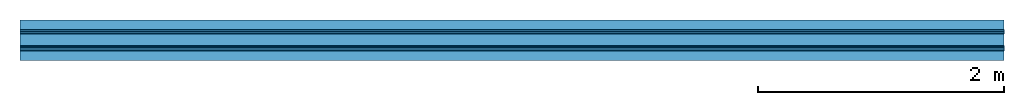
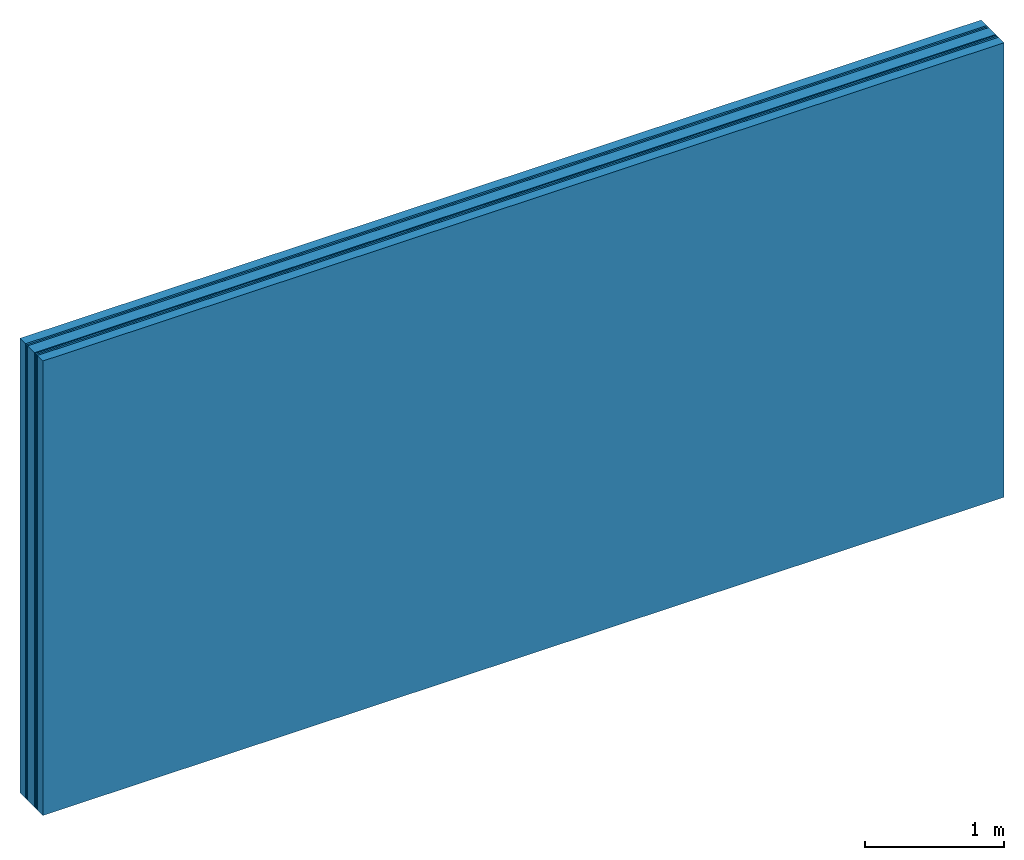
# One storey: 6 plates, 2 members, 1 element without a shape of its own.
"""IFC4 building model written with IfcOpenShell, lengths in metres."""

from ifc_helpers import new_model, si_unit, derived_unit, direction, frame, frame_2d, origin, place, context, project, spatial, rectangle, extrude, material, layer, layer_set, type_object, element, aggregate, save


model = new_model("IFC4")

# Units and contexts
plan_context = context("Plan", 3, precision=1e-05, world=origin(), true_north=direction((0.0, 1.0)))
model_context = context("Model", 3, precision=1e-05, world=origin(), true_north=direction((0.0, 1.0)))
ifc_project = project(units=[si_unit("LENGTHUNIT", "METRE"), derived_unit("SOUNDPRESSUREUNIT", [(si_unit("PRESSUREUNIT", "PASCAL", prefix="MICRO"), 0)]), si_unit("ENERGYUNIT", "JOULE", prefix="MEGA"), si_unit("MASSUNIT", "GRAM", prefix="KILO"), derived_unit("THERMALTRANSMITTANCEUNIT", [(si_unit("POWERUNIT", "WATT"), 1), (si_unit("AREAUNIT", "SQUARE_METRE"), -1), (si_unit("THERMODYNAMICTEMPERATUREUNIT", "KELVIN"), -1)]), derived_unit("AREADENSITYUNIT", [(si_unit("MASSUNIT", "GRAM", prefix="KILO"), 1), (si_unit("AREAUNIT", "SQUARE_METRE"), -1)]), derived_unit("USERDEFINED", [(si_unit("ENERGYUNIT", "JOULE", prefix="MEGA"), 1), (si_unit("AREAUNIT", "SQUARE_METRE"), -1)])], contexts=[plan_context, model_context])

# Site, building, storey
site = spatial("IfcSite", under=ifc_project)
building_placement = place(None, origin())
building = spatial("IfcBuilding", under=site, at=building_placement)
storey_placement = place(building_placement, origin())
storey = spatial("IfcBuildingStorey", under=building, at=storey_placement)

# Wall, members, plates
ifc_material_1 = material(Name="of the art")
ifc_layer_1 = layer(ifc_material_1, 0.0, Name="Bond")
ifc_layer_2 = layer(None, 0.08, Name="Support")
ifc_layer_3 = layer(ifc_material_1, 0.0, Name="Bond")
ifc_material_2 = material(Category="03.007")
ifc_layer_4 = layer(ifc_material_2, 0.015, Name="outside 1st layer")
ifc_layer_5 = layer(ifc_material_2, 0.015, Name="outside 2nd layer")
ifc_material_3 = material(Category="10.008")
ifc_layer_6 = layer(ifc_material_3, 0.1, Name="Intermediate insulation")
ifc_material_4 = material(Name="Air")
ifc_layer_7 = layer(ifc_material_4, 0.01, Name="Air gap")
ifc_layer_8 = layer(ifc_material_2, 0.015, Name="2nd layer")
ifc_layer_9 = layer(ifc_material_2, 0.015, Name="outside 1st layer")
ifc_layer_10 = layer(ifc_material_1, 0.0, Name="Bond")
ifc_layer_11 = layer(None, 0.08, Name="Support")
ifc_layer_12 = layer(ifc_material_1, 0.0, Name="Bond")
ifc_layer_set = layer_set([ifc_layer_1, ifc_layer_2, ifc_layer_3, ifc_layer_4, ifc_layer_5, ifc_layer_6, ifc_layer_7, ifc_layer_8, ifc_layer_9, ifc_layer_10, ifc_layer_11, ifc_layer_12])
wall_type = type_object("IfcWallType", Name="B0262", PredefinedType="NOTDEFINED", material=ifc_layer_set)
wall_placement = place(None, frame((0.0, 0.0, 0.0), z_axis=(0.0, -1.0, 0.0), x_axis=(1.0, 0.0, 0.0)))
wall = element("IfcWall", 1, at=wall_placement, inside=storey, type_object=wall_type, material=ifc_layer_set, Name="Wall #1")
ifc_material_5 = material(Name="Solid timber panel")
member_1_placement = place(wall_placement, origin())
member_1 = element("IfcMember", 2, at=member_1_placement, material=ifc_material_5, Name="Support", context=plan_context, shape_type="SweptSolid", body=[
    extrude(rectangle(XDim=1.0, YDim=0.08, at=frame_2d((0.5, 0.04), x_axis=(1.0, 0.0))), frame((0.0, 4.0, 0.0), z_axis=(0.0, -1.0, 0.0), x_axis=(1.0, 0.0, 0.0)), (0.0, 0.0, 1.0), 4.0),
    extrude(rectangle(XDim=1.0, YDim=0.08, at=frame_2d((0.5, 0.04), x_axis=(1.0, 0.0))), frame((1.0, 4.0, 0.0), z_axis=(0.0, -1.0, 0.0), x_axis=(1.0, 0.0, 0.0)), (0.0, 0.0, 1.0), 4.0),
    extrude(rectangle(XDim=1.0, YDim=0.08, at=frame_2d((0.5, 0.04), x_axis=(1.0, 0.0))), frame((2.0, 4.0, 0.0), z_axis=(0.0, -1.0, 0.0), x_axis=(1.0, 0.0, 0.0)), (0.0, 0.0, 1.0), 4.0),
    extrude(rectangle(XDim=1.0, YDim=0.08, at=frame_2d((0.5, 0.04), x_axis=(1.0, 0.0))), frame((3.0, 4.0, 0.0), z_axis=(0.0, -1.0, 0.0), x_axis=(1.0, 0.0, 0.0)), (0.0, 0.0, 1.0), 4.0),
    extrude(rectangle(XDim=1.0, YDim=0.08, at=frame_2d((0.5, 0.04), x_axis=(1.0, 0.0))), frame((4.0, 4.0, 0.0), z_axis=(0.0, -1.0, 0.0), x_axis=(1.0, 0.0, 0.0)), (0.0, 0.0, 1.0), 4.0),
    extrude(rectangle(XDim=1.0, YDim=0.08, at=frame_2d((0.5, 0.04), x_axis=(1.0, 0.0))), frame((5.0, 4.0, 0.0), z_axis=(0.0, -1.0, 0.0), x_axis=(1.0, 0.0, 0.0)), (0.0, 0.0, 1.0), 4.0),
    extrude(rectangle(XDim=1.0, YDim=0.08, at=frame_2d((0.5, 0.04), x_axis=(1.0, 0.0))), frame((6.0, 4.0, 0.0), z_axis=(0.0, -1.0, 0.0), x_axis=(1.0, 0.0, 0.0)), (0.0, 0.0, 1.0), 4.0),
    extrude(rectangle(XDim=1.0, YDim=0.08, at=frame_2d((0.5, 0.04), x_axis=(1.0, 0.0))), frame((7.0, 4.0, 0.0), z_axis=(0.0, -1.0, 0.0), x_axis=(1.0, 0.0, 0.0)), (0.0, 0.0, 1.0), 4.0),
])
member_2_placement = place(wall_placement, origin())
member_2 = element("IfcMember", 3, at=member_2_placement, material=ifc_material_5, Name="Support", context=plan_context, shape_type="SweptSolid", body=[
    extrude(rectangle(XDim=1.0, YDim=0.08, at=frame_2d((0.5, 0.04), x_axis=(1.0, 0.0))), frame((0.0, 4.0, 0.25), z_axis=(0.0, -1.0, 0.0), x_axis=(1.0, 0.0, 0.0)), (0.0, 0.0, 1.0), 4.0),
    extrude(rectangle(XDim=1.0, YDim=0.08, at=frame_2d((0.5, 0.04), x_axis=(1.0, 0.0))), frame((1.0, 4.0, 0.25), z_axis=(0.0, -1.0, 0.0), x_axis=(1.0, 0.0, 0.0)), (0.0, 0.0, 1.0), 4.0),
    extrude(rectangle(XDim=1.0, YDim=0.08, at=frame_2d((0.5, 0.04), x_axis=(1.0, 0.0))), frame((2.0, 4.0, 0.25), z_axis=(0.0, -1.0, 0.0), x_axis=(1.0, 0.0, 0.0)), (0.0, 0.0, 1.0), 4.0),
    extrude(rectangle(XDim=1.0, YDim=0.08, at=frame_2d((0.5, 0.04), x_axis=(1.0, 0.0))), frame((3.0, 4.0, 0.25), z_axis=(0.0, -1.0, 0.0), x_axis=(1.0, 0.0, 0.0)), (0.0, 0.0, 1.0), 4.0),
    extrude(rectangle(XDim=1.0, YDim=0.08, at=frame_2d((0.5, 0.04), x_axis=(1.0, 0.0))), frame((4.0, 4.0, 0.25), z_axis=(0.0, -1.0, 0.0), x_axis=(1.0, 0.0, 0.0)), (0.0, 0.0, 1.0), 4.0),
    extrude(rectangle(XDim=1.0, YDim=0.08, at=frame_2d((0.5, 0.04), x_axis=(1.0, 0.0))), frame((5.0, 4.0, 0.25), z_axis=(0.0, -1.0, 0.0), x_axis=(1.0, 0.0, 0.0)), (0.0, 0.0, 1.0), 4.0),
    extrude(rectangle(XDim=1.0, YDim=0.08, at=frame_2d((0.5, 0.04), x_axis=(1.0, 0.0))), frame((6.0, 4.0, 0.25), z_axis=(0.0, -1.0, 0.0), x_axis=(1.0, 0.0, 0.0)), (0.0, 0.0, 1.0), 4.0),
    extrude(rectangle(XDim=1.0, YDim=0.08, at=frame_2d((0.5, 0.04), x_axis=(1.0, 0.0))), frame((7.0, 4.0, 0.25), z_axis=(0.0, -1.0, 0.0), x_axis=(1.0, 0.0, 0.0)), (0.0, 0.0, 1.0), 4.0),
])
plate_1_placement = place(wall_placement, origin())
plate_1 = element("IfcPlate", 4, at=plate_1_placement, material=ifc_material_2, Name="outside 1st layer", context=plan_context, shape_type="SweptSolid", body=[
    extrude(rectangle(XDim=8.0, YDim=4.0, at=frame_2d((4.0, 2.0), x_axis=(1.0, 0.0))), frame((0.0, 0.0, 0.08), z_axis=(0.0, 0.0, 1.0), x_axis=(1.0, 0.0, 0.0)), (0.0, 0.0, 1.0), 0.015),
])
plate_2_placement = place(wall_placement, origin())
plate_2 = element("IfcPlate", 5, at=plate_2_placement, material=ifc_material_2, Name="outside 2nd layer", context=plan_context, shape_type="SweptSolid", body=[
    extrude(rectangle(XDim=8.0, YDim=4.0, at=frame_2d((4.0, 2.0), x_axis=(1.0, 0.0))), frame((0.0, 0.0, 0.095), z_axis=(0.0, 0.0, 1.0), x_axis=(1.0, 0.0, 0.0)), (0.0, 0.0, 1.0), 0.015),
])
plate_3_placement = place(wall_placement, origin())
plate_3 = element("IfcPlate", 6, at=plate_3_placement, material=ifc_material_3, Name="Intermediate insulation", context=plan_context, shape_type="SweptSolid", body=[
    extrude(rectangle(XDim=8.0, YDim=4.0, at=frame_2d((4.0, 2.0), x_axis=(1.0, 0.0))), frame((0.0, 0.0, 0.11), z_axis=(0.0, 0.0, 1.0), x_axis=(1.0, 0.0, 0.0)), (0.0, 0.0, 1.0), 0.1),
])
plate_4_placement = place(wall_placement, origin())
plate_4 = element("IfcPlate", 7, at=plate_4_placement, material=ifc_material_4, Name="Air gap", context=plan_context, shape_type="SweptSolid", body=[
    extrude(rectangle(XDim=8.0, YDim=4.0, at=frame_2d((4.0, 2.0), x_axis=(1.0, 0.0))), frame((0.0, 0.0, 0.21), z_axis=(0.0, 0.0, 1.0), x_axis=(1.0, 0.0, 0.0)), (0.0, 0.0, 1.0), 0.01),
])
plate_5_placement = place(wall_placement, origin())
plate_5 = element("IfcPlate", 8, at=plate_5_placement, material=ifc_material_2, Name="2nd layer", context=plan_context, shape_type="SweptSolid", body=[
    extrude(rectangle(XDim=8.0, YDim=4.0, at=frame_2d((4.0, 2.0), x_axis=(1.0, 0.0))), frame((0.0, 0.0, 0.22), z_axis=(0.0, 0.0, 1.0), x_axis=(1.0, 0.0, 0.0)), (0.0, 0.0, 1.0), 0.015),
])
plate_6_placement = place(wall_placement, origin())
plate_6 = element("IfcPlate", 9, at=plate_6_placement, material=ifc_material_2, Name="outside 1st layer", context=plan_context, shape_type="SweptSolid", body=[
    extrude(rectangle(XDim=8.0, YDim=4.0, at=frame_2d((4.0, 2.0), x_axis=(1.0, 0.0))), frame((0.0, 0.0, 0.235), z_axis=(0.0, 0.0, 1.0), x_axis=(1.0, 0.0, 0.0)), (0.0, 0.0, 1.0), 0.015),
])
aggregate(wall, [member_1, plate_1, plate_2, plate_3, plate_4, plate_5, plate_6, member_2])

save(model, "model.ifc")
